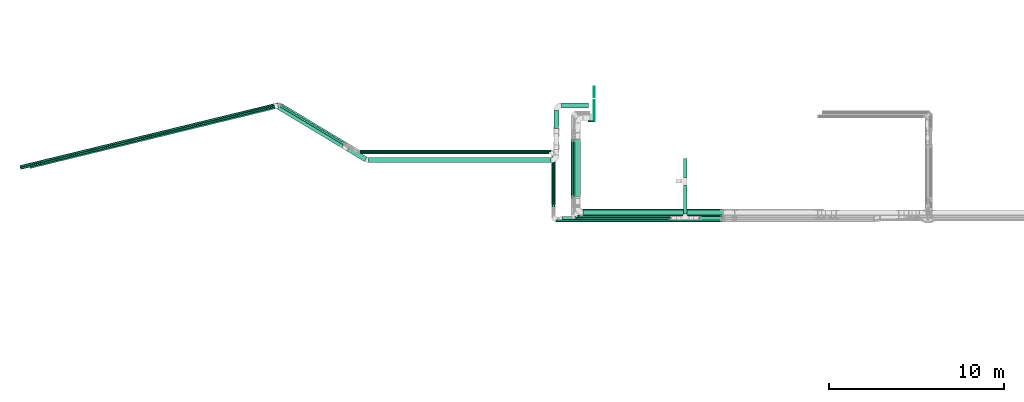
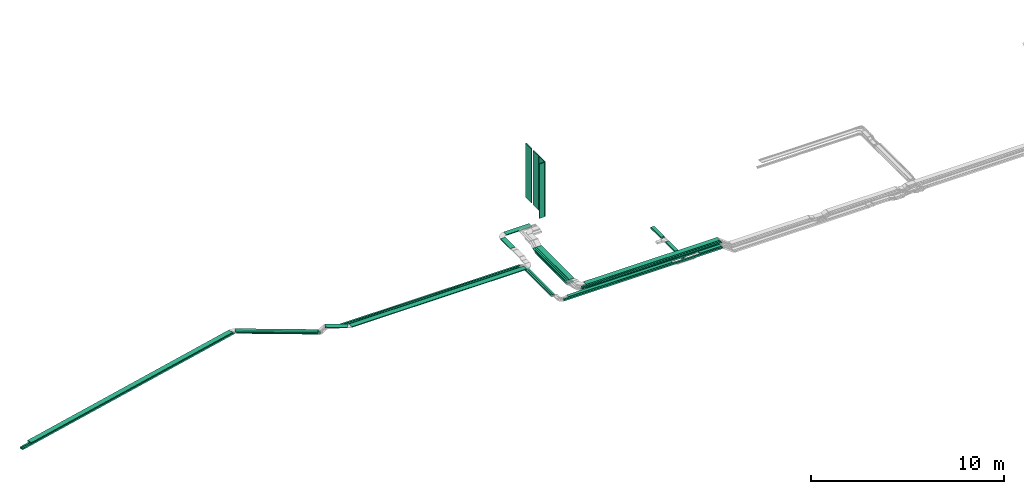
# One storey, part 1 of 27: 31 flow segments.
"""IFC2X3 building model written with IfcOpenShell, lengths in millimetres."""

import ifcopenshell
import ifcopenshell.guid

model = None  # the IFC model being written
_history = None  # IfcOwnerHistory: only IFC2X3 demands one
_inside = {}  # id of a spatial element -> (the spatial element, [elements in it])
_under = {}  # id of a project, library or spatial element -> (it, [spatial elements below it])
_declared = {}  # id of a project -> (the project, [libraries it declares])
_typed = {}  # id of a type object -> (the type object, [elements of that type])
_made_of = {}  # id of a material, layer set ... -> (it, [elements and type objects made of it])


def new_model(schema):
    """Start an empty IFC model of exactly this schema.

    Asked for "IFC4X3", IfcOpenShell would pick the latest addendum, in which some entities
    have other attributes; the version numbers below select the first issue.
    IFC2X3 requires an IfcOwnerHistory on every rooted entity: one is made here for all.
    """
    global model, _history
    if schema == "IFC4X3":
        model = ifcopenshell.file(schema_version=(4, 3, 0, 0))
    else:
        model = ifcopenshell.file(schema=schema)
    _inside.clear()
    _under.clear()
    _declared.clear()
    _typed.clear()
    _made_of.clear()
    _history = None
    if model.schema == "IFC2X3":
        org = make("IfcOrganization", Name="unknown")
        user = make(
            "IfcPersonAndOrganization",
            ThePerson=make("IfcPerson", FamilyName="unknown"),
            TheOrganization=org,
        )
        app = make(
            "IfcApplication",
            ApplicationDeveloper=org,
            Version="unknown",
            ApplicationFullName="unknown",
            ApplicationIdentifier="unknown",
        )
        _history = make(
            "IfcOwnerHistory",
            OwningUser=user,
            OwningApplication=app,
            ChangeAction="ADDED",
            CreationDate=0,
        )
    return model


def make(cls, **values):
    """One entity of the class cls with the attributes given. An attribute that is None is left unset."""
    return model.create_entity(
        cls, **{name: value for name, value in values.items() if value is not None}
    )


def entity(cls, *values):
    """Any entity or typed value of the class cls, its attributes in the order of the schema. None: left unset."""
    e = model.create_entity(cls)
    for i, value in enumerate(values):
        if value is not None:
            e[i] = value
    return e


def rooted(cls, **values):
    """An entity with a GlobalId (a new one), such as an element, a storey or a relation."""
    return make(cls, GlobalId=ifcopenshell.guid.new(), OwnerHistory=_history, **values)


def si_unit(unit_type, name, prefix=None):
    """IfcSIUnit, for example si_unit("LENGTHUNIT", "METRE", prefix="MILLI")."""
    return make("IfcSIUnit", UnitType=unit_type, Prefix=prefix, Name=name)


def converted_unit(unit_type, name, factor, base, dimensions=None, offset=None):
    """IfcConversionBasedUnit, such as the inch: factor (a typed value) times the base unit."""
    return make(
        "IfcConversionBasedUnit"
        if offset is None
        else "IfcConversionBasedUnitWithOffset",
        ConversionOffset=offset,
        Dimensions=None
        if dimensions is None
        else entity("IfcDimensionalExponents", *dimensions),
        UnitType=unit_type,
        Name=name,
        ConversionFactor=make(
            "IfcMeasureWithUnit", ValueComponent=factor, UnitComponent=base
        ),
    )


def derived_unit(unit_type, elements):
    """IfcDerivedUnit: a product of units, each with its exponent."""
    return make(
        "IfcDerivedUnit",
        Elements=[
            make("IfcDerivedUnitElement", Unit=unit, Exponent=power)
            for unit, power in elements
        ],
        UnitType=unit_type,
    )


def assignment(units):
    """IfcUnitAssignment: the units of a project."""
    return None if units is None else make("IfcUnitAssignment", Units=units)


def point(xyz):
    """IfcCartesianPoint."""
    return None if xyz is None else make("IfcCartesianPoint", Coordinates=xyz)


def direction(xyz):
    """IfcDirection."""
    return None if xyz is None else make("IfcDirection", DirectionRatios=xyz)


def frame(location, z_axis=None, x_axis=None):
    """IfcAxis2Placement3D, a coordinate frame: its origin and axes. An axis left out is left unset."""
    return make(
        "IfcAxis2Placement3D",
        Location=point(location),
        Axis=direction(z_axis),
        RefDirection=direction(x_axis),
    )


def frame_2d(location, x_axis=None):
    """IfcAxis2Placement2D, a coordinate frame in the plane: its origin and x axis."""
    return make(
        "IfcAxis2Placement2D", Location=point(location), RefDirection=direction(x_axis)
    )


def origin():
    """The frame at (0, 0, 0) with its axes left unset."""
    return frame((0.0, 0.0, 0.0))


def origin_2d_with_axis():
    """The frame at (0, 0) in the plane with the x axis (1, 0) written out."""
    return frame_2d((0.0, 0.0), x_axis=(1.0, 0.0))


def place(relative_to, where):
    """IfcLocalPlacement: puts the frame where relative to a parent placement (None: the world)."""
    return make(
        "IfcLocalPlacement", PlacementRelTo=relative_to, RelativePlacement=where
    )


def context(
    kind, dimensions, precision=None, world=None, true_north=None, identifier=None
):
    """IfcGeometricRepresentationContext, for example the 3D "Model" context."""
    return make(
        "IfcGeometricRepresentationContext",
        ContextIdentifier=identifier,
        ContextType=kind,
        CoordinateSpaceDimension=dimensions,
        Precision=precision,
        WorldCoordinateSystem=world,
        TrueNorth=true_north,
    )


def subcontext(parent, identifier, kind, view, scale=None):
    """IfcGeometricRepresentationSubContext, for example "Body" below "Model"."""
    return make(
        "IfcGeometricRepresentationSubContext",
        ContextIdentifier=identifier,
        ContextType=kind,
        ParentContext=parent,
        TargetScale=scale,
        TargetView=view,
    )


def project(units=None, contexts=None):
    """IfcProject with its units and contexts."""
    return rooted(
        "IfcProject",
        Name="project",
        RepresentationContexts=contexts,
        UnitsInContext=assignment(units),
    )


def spatial(cls, under=None, at=None, **own):
    """A site, building, storey or space (cls), placed at a placement, below another one or the project."""
    s = rooted(cls, ObjectPlacement=at, **own)
    if under is not None:
        _under.setdefault(under.id(), (under, []))[1].append(s)
    return s


def profile(cls, at=None, kind="AREA", **sizes):
    """A parametric profile (cls). Its sizes go by their IFC names, for example OverallWidth=200.0."""
    return make(cls, ProfileType=kind, Position=at, **sizes)


def rectangle(**sizes):
    """IfcRectangleProfileDef."""
    return profile("IfcRectangleProfileDef", **sizes)


def extrude(swept, where, along, depth):
    """IfcExtrudedAreaSolid: the profile swept, set in the frame where, extruded along a direction by depth."""
    return make(
        "IfcExtrudedAreaSolid",
        SweptArea=swept,
        Position=where,
        ExtrudedDirection=direction(along),
        Depth=depth,
    )


def shape(context_of_items, identifier, shape_type, items):
    """IfcShapeRepresentation: the items that make up one representation, for example the "Body"."""
    return make(
        "IfcShapeRepresentation",
        ContextOfItems=context_of_items,
        RepresentationIdentifier=identifier,
        RepresentationType=shape_type,
        Items=items,
    )


def made_of(thing, what):
    """Note that an element or type object is made of a material, layer set ...; save() writes the relation."""
    if what is not None:
        _made_of.setdefault(what.id(), (what, []))[1].append(thing)
    return thing


def type_object(cls, material=None, **own):
    """A type object (cls), such as IfcWallType, which elements share."""
    return made_of(rooted(cls, **own), material)


def element(
    cls,
    number,
    at=None,
    inside=None,
    cuts=None,
    type_object=None,
    material=None,
    context=None,
    identifier="Body",
    shape_type=None,
    held_by="IfcProductDefinitionShape",
    body=None,
    shapes=None,
    **own,
):
    """One element of the class cls, such as IfcWall. Its Tag is "e" and its number.

    at: its placement. inside: the storey or other place that contains it. cuts: it is an
    opening in that element (IfcRelVoidsElement). A single representation is given by context,
    identifier, shape_type and body (its items); several are given by shapes. held_by: the class
    of the entity that holds the representations. save() writes the other relations.
    """
    e = rooted(cls, Tag="e%d" % number, ObjectPlacement=at, **own)
    if body is not None:
        shapes = [shape(context, identifier, shape_type, body)]
    if shapes is not None:
        e.Representation = make(held_by, Representations=shapes)
    if inside is not None:
        _inside.setdefault(inside.id(), (inside, []))[1].append(e)
    if cuts is not None:
        rooted(
            "IfcRelVoidsElement", RelatingBuildingElement=cuts, RelatedOpeningElement=e
        )
    if type_object is not None:
        _typed.setdefault(type_object.id(), (type_object, []))[1].append(e)
    return made_of(e, material)


def aggregate(whole, parts):
    """IfcRelAggregates: a whole, such as a stair, and the parts it consists of."""
    return rooted("IfcRelAggregates", RelatingObject=whole, RelatedObjects=parts)


def save(model, path):
    """Write the relations noted so far, then the file.

    IfcRelAggregates (storeys below a building ...), IfcRelContainedInSpatialStructure (elements
    in a storey), IfcRelDefinesByType, IfcRelAssociatesMaterial and IfcRelDeclares: one each for
    every whole, place, type object, material and project.
    """
    for whole, parts in _under.values():
        aggregate(whole, parts)
    for where, things in _inside.values():
        rooted(
            "IfcRelContainedInSpatialStructure",
            RelatedElements=things,
            RelatingStructure=where,
        )
    for kind, things in _typed.values():
        rooted("IfcRelDefinesByType", RelatedObjects=things, RelatingType=kind)
    for what, things in _made_of.values():
        rooted("IfcRelAssociatesMaterial", RelatedObjects=things, RelatingMaterial=what)
    for by, libraries in _declared.values():
        rooted("IfcRelDeclares", RelatingContext=by, RelatedDefinitions=libraries)
    model.write(path)


model = new_model("IFC2X3")

# Units and contexts
model_context = context("Model", 3, precision=0.01, world=origin(), true_north=direction((6.12303176911189e-17, 1.0)))
body_context = subcontext(model_context, "Body", "Model", "MODEL_VIEW")
ifc_project = project(units=[si_unit("LENGTHUNIT", "METRE", prefix="MILLI"), si_unit("AREAUNIT", "SQUARE_METRE"), si_unit("VOLUMEUNIT", "CUBIC_METRE"), converted_unit("PLANEANGLEUNIT", "DEGREE", entity("IfcRatioMeasure", 0.0174532925199433), si_unit("PLANEANGLEUNIT", "RADIAN"), dimensions=[0, 0, 0, 0, 0, 0, 0]), si_unit("MASSUNIT", "GRAM", prefix="KILO"), derived_unit("MASSDENSITYUNIT", [(si_unit("MASSUNIT", "GRAM", prefix="KILO"), 1), (si_unit("LENGTHUNIT", "METRE"), -3)]), derived_unit("MOMENTOFINERTIAUNIT", [(si_unit("LENGTHUNIT", "METRE"), 4)]), si_unit("TIMEUNIT", "SECOND"), si_unit("FREQUENCYUNIT", "HERTZ"), si_unit("THERMODYNAMICTEMPERATUREUNIT", "DEGREE_CELSIUS"), derived_unit("THERMALTRANSMITTANCEUNIT", [(si_unit("MASSUNIT", "GRAM", prefix="KILO"), 1), (si_unit("THERMODYNAMICTEMPERATUREUNIT", "KELVIN"), -1), (si_unit("TIMEUNIT", "SECOND"), -3)]), derived_unit("VOLUMETRICFLOWRATEUNIT", [(si_unit("LENGTHUNIT", "METRE"), 3), (si_unit("TIMEUNIT", "SECOND"), -1)]), derived_unit("MASSFLOWRATEUNIT", [(si_unit("MASSUNIT", "GRAM", prefix="KILO"), 1), (si_unit("TIMEUNIT", "SECOND"), -1)]), derived_unit("ROTATIONALFREQUENCYUNIT", [(si_unit("TIMEUNIT", "SECOND"), -1)]), si_unit("ELECTRICCURRENTUNIT", "AMPERE"), si_unit("ELECTRICVOLTAGEUNIT", "VOLT"), si_unit("POWERUNIT", "WATT"), si_unit("FORCEUNIT", "NEWTON", prefix="KILO"), si_unit("ILLUMINANCEUNIT", "LUX"), si_unit("LUMINOUSFLUXUNIT", "LUMEN"), si_unit("LUMINOUSINTENSITYUNIT", "CANDELA"), derived_unit("USERDEFINED", [(si_unit("MASSUNIT", "GRAM", prefix="KILO"), -1), (si_unit("LENGTHUNIT", "METRE"), -2), (si_unit("TIMEUNIT", "SECOND"), 3), (si_unit("LUMINOUSFLUXUNIT", "LUMEN"), 1)]), derived_unit("LINEARVELOCITYUNIT", [(si_unit("LENGTHUNIT", "METRE"), 1), (si_unit("TIMEUNIT", "SECOND"), -1)]), si_unit("PRESSUREUNIT", "PASCAL"), derived_unit("USERDEFINED", [(si_unit("LENGTHUNIT", "METRE"), -2), (si_unit("MASSUNIT", "GRAM", prefix="KILO"), 1), (si_unit("TIMEUNIT", "SECOND"), -2)]), derived_unit("LINEARFORCEUNIT", [(si_unit("MASSUNIT", "GRAM", prefix="KILO"), 1), (si_unit("LENGTHUNIT", "METRE"), 1), (si_unit("TIMEUNIT", "SECOND"), -2), (si_unit("LENGTHUNIT", "METRE"), -1)]), derived_unit("PLANARFORCEUNIT", [(si_unit("MASSUNIT", "GRAM", prefix="KILO"), 1), (si_unit("LENGTHUNIT", "METRE"), 1), (si_unit("TIMEUNIT", "SECOND"), -2), (si_unit("LENGTHUNIT", "METRE"), -2)])], contexts=[model_context])

# Site, building, storey
site_placement = place(None, origin())
site = spatial("IfcSite", under=ifc_project, at=site_placement, CompositionType="ELEMENT")
building_placement = place(site_placement, origin())
building = spatial("IfcBuilding", under=site, at=building_placement, CompositionType="ELEMENT")
storey_placement = place(building_placement, origin())
storey = spatial("IfcBuildingStorey", under=building, at=storey_placement, CompositionType="ELEMENT", Elevation=0.0)

# Flow segments
cable_carrier_segment_type_1 = type_object("IfcCableCarrierSegmentType", PredefinedType="CABLETRAYSEGMENT")
flow_segment_1_placement = place(storey_placement, frame((15851.0, 8570.0, 3100.0)))
element("IfcFlowSegment", 1, at=flow_segment_1_placement, inside=storey, type_object=cable_carrier_segment_type_1, context=body_context, shape_type="SweptSolid", body=[
    extrude(rectangle(XDim=7974.65921899979, YDim=400.0, at=origin_2d_with_axis()), frame((3987.33, 200.0, 0.0)), (0.0, 0.0, 1.0), 100.0),
])
flow_segment_2_placement = place(storey_placement, frame((21593.6, 10793.36, 2950.0)))
element("IfcFlowSegment", 2, at=flow_segment_2_placement, inside=storey, type_object=cable_carrier_segment_type_1, context=body_context, shape_type="SweptSolid", body=[
    extrude(rectangle(XDim=1071.71608612061, YDim=199.999999999998, at=origin_2d_with_axis()), frame((100.0, 535.86, 0.0), z_axis=(0.0, 0.0, 1.0), x_axis=(0.0, -1.0, 0.0)), (0.0, 0.0, 1.0), 99.9999999999995),
])
flow_segment_3_placement = place(storey_placement, frame((14644.72, 8360.0, 3100.0)))
element("IfcFlowSegment", 3, at=flow_segment_3_placement, inside=storey, type_object=cable_carrier_segment_type_1, context=body_context, shape_type="SweptSolid", body=[
    extrude(rectangle(XDim=6224.94739294661, YDim=200.0, at=origin_2d_with_axis()), frame((3112.47, 100.0, 0.0)), (0.0, 0.0, 1.0), 100.0),
])
flow_segment_4_placement = place(storey_placement, frame((14163.72, 9105.62, 2950.0)))
element("IfcFlowSegment", 4, at=flow_segment_4_placement, inside=storey, type_object=cable_carrier_segment_type_1, context=body_context, shape_type="SweptSolid", body=[
    extrude(rectangle(XDim=2998.38255226861, YDim=99.9999999999989, at=origin_2d_with_axis()), frame((50.0, 1499.19, 0.0), z_axis=(0.0, 0.0, 1.0), x_axis=(0.0, -1.0, 0.0)), (0.0, 0.0, 1.0), 100.0),
])
flow_segment_5_placement = place(storey_placement, frame((3071.29, 12255.0, 2950.0)))
element("IfcFlowSegment", 5, at=flow_segment_5_placement, inside=storey, type_object=cable_carrier_segment_type_1, context=body_context, shape_type="SweptSolid", body=[
    extrude(rectangle(XDim=10941.4294128361, YDim=99.9999999999989, at=origin_2d_with_axis()), frame((5470.71, 50.0, 0.0), z_axis=(0.0, 0.0, 1.0), x_axis=(-1.0, 0.0, 0.0)), (0.0, 0.0, 1.0), 100.0),
])
flow_segment_6_placement = place(storey_placement, frame((-1476.17, 12676.61, 2600.0)))
element("IfcFlowSegment", 6, at=flow_segment_6_placement, inside=storey, type_object=cable_carrier_segment_type_1, context=body_context, shape_type="SweptSolid", body=[
    extrude(rectangle(XDim=4404.58031867628, YDim=99.9999999999999, at=origin_2d_with_axis()), frame((1913.48, 1177.12, 0.0), z_axis=(0.0, 0.0, 1.0), x_axis=(0.857167300702113, -0.515038074910054, 0.0)), (0.0, 0.0, 1.0), 100.0),
])
flow_segment_7_placement = place(storey_placement, frame((-16390.68, 11360.8, 2600.0)))
element("IfcFlowSegment", 7, at=flow_segment_7_placement, inside=storey, type_object=cable_carrier_segment_type_1, context=body_context, shape_type="SweptSolid", body=[
    extrude(rectangle(XDim=15208.8618462409, YDim=99.9999999999989, at=origin_2d_with_axis()), frame((7399.95, 1849.46, 0.0), z_axis=(0.0, 0.0, 1.0), x_axis=(-0.97155336378743, -0.236820736662416, 0.0)), (0.0, 0.0, 1.0), 100.0),
])
flow_segment_8_placement = place(storey_placement, frame((14304.72, 8250.0, 3100.0)))
element("IfcFlowSegment", 8, at=flow_segment_8_placement, inside=storey, type_object=cable_carrier_segment_type_1, context=body_context, shape_type="SweptSolid", body=[
    extrude(rectangle(XDim=9520.9318527469, YDim=99.9999999999989, at=origin_2d_with_axis()), frame((4760.47, 50.0, 0.0)), (0.0, 0.0, 1.0), 100.0),
])
flow_segment_9_placement = place(storey_placement, frame((14053.72, 9105.62, 2950.0)))
element("IfcFlowSegment", 9, at=flow_segment_9_placement, inside=storey, type_object=cable_carrier_segment_type_1, context=body_context, shape_type="SweptSolid", body=[
    extrude(rectangle(XDim=2878.38255226848, YDim=99.9999999999989, at=origin_2d_with_axis()), frame((50.0, 1439.19, 0.0), z_axis=(0.0, 0.0, 1.0), x_axis=(0.0, -1.0, 0.0)), (0.0, 0.0, 1.0), 100.0),
])
flow_segment_10_placement = place(storey_placement, frame((3057.43, 12135.0, 2950.0)))
element("IfcFlowSegment", 10, at=flow_segment_10_placement, inside=storey, type_object=cable_carrier_segment_type_1, context=body_context, shape_type="SweptSolid", body=[
    extrude(rectangle(XDim=10845.2923178592, YDim=99.9999999999989, at=origin_2d_with_axis()), frame((5422.65, 50.0, 0.0), z_axis=(0.0, 0.0, 1.0), x_axis=(-1.0, 0.0, 0.0)), (0.0, 0.0, 1.0), 100.0),
])
flow_segment_11_placement = place(storey_placement, frame((-1494.06, 12582.32, 2600.0)))
element("IfcFlowSegment", 11, at=flow_segment_11_placement, inside=storey, type_object=cable_carrier_segment_type_1, context=body_context, shape_type="SweptSolid", body=[
    extrude(rectangle(XDim=4359.35500303556, YDim=100.0, at=origin_2d_with_axis()), frame((1894.1, 1165.48, 0.0), z_axis=(0.0, 0.0, 1.0), x_axis=(0.857167300702109, -0.51503807491006, 0.0)), (0.0, 0.0, 1.0), 100.0),
])
flow_segment_12_placement = place(storey_placement, frame((-16364.63, 11253.93, 2600.0)))
element("IfcFlowSegment", 12, at=flow_segment_12_placement, inside=storey, type_object=cable_carrier_segment_type_1, context=body_context, shape_type="SweptSolid", body=[
    extrude(rectangle(XDim=15163.6365305987, YDim=99.9999999999992, at=origin_2d_with_axis()), frame((7377.98, 1844.11, 0.0), z_axis=(0.0, 0.0, 1.0), x_axis=(-0.97155336378743, -0.236820736662417, 0.0)), (0.0, 0.0, 1.0), 99.9999999999999),
])
flow_segment_13_placement = place(storey_placement, frame((15290.0, 9581.08, 3230.0)))
element("IfcFlowSegment", 13, at=flow_segment_13_placement, inside=storey, type_object=cable_carrier_segment_type_1, context=body_context, shape_type="SweptSolid", body=[
    extrude(rectangle(XDim=3404.78726853567, YDim=99.9999999999989, at=origin_2d_with_axis()), frame((50.0, 1702.39, 0.0), z_axis=(0.0, 0.0, 1.0), x_axis=(0.0, 1.0, 0.0)), (0.0, 0.0, 1.0), 50.0000000000005),
])
flow_segment_14_placement = place(storey_placement, frame((15180.0, 9581.08, 3230.0)))
element("IfcFlowSegment", 14, at=flow_segment_14_placement, inside=storey, type_object=cable_carrier_segment_type_1, context=body_context, shape_type="SweptSolid", body=[
    extrude(rectangle(XDim=3404.78726853591, YDim=99.9999999999989, at=origin_2d_with_axis()), frame((50.0, 1702.39, 0.0), z_axis=(0.0, 0.0, 1.0), x_axis=(0.0, 1.0, 0.0)), (0.0, 0.0, 1.0), 50.0000000000005),
])
flow_segment_15_placement = place(storey_placement, frame((22517.53, 8360.0, 3100.0)))
element("IfcFlowSegment", 15, at=flow_segment_15_placement, inside=storey, type_object=cable_carrier_segment_type_1, context=body_context, shape_type="SweptSolid", body=[
    extrude(rectangle(XDim=1308.13077267465, YDim=200.0, at=origin_2d_with_axis()), frame((654.07, 100.0, 0.0)), (0.0, 0.0, 1.0), 100.0),
])
flow_segment_16_placement = place(storey_placement, frame((21593.6, 8690.0, 2950.0)))
element("IfcFlowSegment", 16, at=flow_segment_16_placement, inside=storey, type_object=cable_carrier_segment_type_1, context=body_context, shape_type="SweptSolid", body=[
    extrude(rectangle(XDim=1643.36443772362, YDim=199.999999999998, at=origin_2d_with_axis()), frame((100.0, 821.68, 0.0), z_axis=(0.0, 0.0, 1.0), x_axis=(0.0, -1.0, 0.0)), (0.0, 0.0, 1.0), 100.0),
])
flow_segment_17_placement = place(storey_placement, frame((15400.0, 9581.08, 3230.0)))
element("IfcFlowSegment", 17, at=flow_segment_17_placement, inside=storey, type_object=cable_carrier_segment_type_1, context=body_context, shape_type="SweptSolid", body=[
    extrude(rectangle(XDim=3404.78726853175, YDim=300.000000000001, at=origin_2d_with_axis()), frame((150.0, 1702.39, 0.0), z_axis=(0.0, 0.0, 1.0), x_axis=(0.0, -1.0, 0.0)), (0.0, 0.0, 1.0), 49.9999999999995),
])
flow_segment_18_placement = place(storey_placement, frame((14631.0, 14757.61, 3200.0)))
element("IfcFlowSegment", 18, at=flow_segment_18_placement, inside=storey, type_object=cable_carrier_segment_type_1, context=body_context, shape_type="SweptSolid", body=[
    extrude(rectangle(XDim=1526.30884229986, YDim=300.000000000001, at=origin_2d_with_axis()), frame((763.15, 150.0, 0.0), z_axis=(0.0, 0.0, 1.0), x_axis=(-1.0, 0.0, 0.0)), (0.0, 0.0, 1.0), 49.9999999999995),
])
flow_segment_19_placement = place(storey_placement, frame((3570.13, 11625.27, 3150.0)))
element("IfcFlowSegment", 19, at=flow_segment_19_placement, inside=storey, type_object=cable_carrier_segment_type_1, context=body_context, shape_type="SweptSolid", body=[
    extrude(rectangle(XDim=10458.8647674354, YDim=300.000000000001, at=origin_2d_with_axis()), frame((5229.43, 150.0, 0.0), z_axis=(0.0, 0.0, 1.0), x_axis=(-1.0, 0.0, 0.0)), (0.0, 0.0, 1.0), 49.9999999999995),
])
flow_segment_20_placement = place(storey_placement, frame((15851.0, 8620.0, 3350.0)))
element("IfcFlowSegment", 20, at=flow_segment_20_placement, inside=storey, type_object=cable_carrier_segment_type_1, context=body_context, shape_type="SweptSolid", body=[
    extrude(rectangle(XDim=8009.29673573433, YDim=299.999999999999, at=origin_2d_with_axis()), frame((4004.65, 150.0, 0.0)), (0.0, 0.0, 1.0), 50.0000000000005),
])
flow_segment_21_placement = place(storey_placement, frame((15541.0, 8510.0, 3350.0)))
element("IfcFlowSegment", 21, at=flow_segment_21_placement, inside=storey, type_object=cable_carrier_segment_type_1, context=body_context, shape_type="SweptSolid", body=[
    extrude(rectangle(XDim=8319.2967357344, YDim=99.9999999999989, at=origin_2d_with_axis()), frame((4159.65, 50.0, 0.0)), (0.0, 0.0, 1.0), 50.0000000000005),
])
flow_segment_22_placement = place(storey_placement, frame((15431.0, 8400.0, 3350.0)))
element("IfcFlowSegment", 22, at=flow_segment_22_placement, inside=storey, type_object=cable_carrier_segment_type_1, context=body_context, shape_type="SweptSolid", body=[
    extrude(rectangle(XDim=8429.29673573445, YDim=99.9999999999989, at=origin_2d_with_axis()), frame((4214.65, 50.0, 0.0)), (0.0, 0.0, 1.0), 50.0000000000005),
])
flow_segment_23_placement = place(storey_placement, frame((15300.0, 9660.36, 2940.0)))
element("IfcFlowSegment", 23, at=flow_segment_23_placement, inside=storey, type_object=cable_carrier_segment_type_1, context=body_context, shape_type="SweptSolid", body=[
    extrude(rectangle(XDim=3284.22401747535, YDim=400.0, at=origin_2d_with_axis()), frame((200.0, 1642.11, 0.0), z_axis=(0.0, 0.0, 1.0), x_axis=(0.0, -1.0, 0.0)), (0.0, 0.0, 1.0), 100.0),
])
flow_segment_24_placement = place(storey_placement, frame((14180.0, 13577.12, 3200.0)))
element("IfcFlowSegment", 24, at=flow_segment_24_placement, inside=storey, type_object=cable_carrier_segment_type_1, context=body_context, shape_type="SweptSolid", body=[
    extrude(rectangle(XDim=1029.48573385168, YDim=300.000000000001, at=origin_2d_with_axis()), frame((150.0, 514.74, 0.0), z_axis=(0.0, 0.0, 1.0), x_axis=(0.0, -1.0, 0.0)), (0.0, 0.0, 1.0), 50.0000000000005),
])
flow_segment_25_placement = place(storey_placement, frame((2333.9, 11690.06, 3150.0)))
element("IfcFlowSegment", 25, at=flow_segment_25_placement, inside=storey, type_object=cable_carrier_segment_type_1, context=body_context, shape_type="SweptSolid", body=[
    extrude(rectangle(XDim=1169.67695262687, YDim=299.999999999999, at=origin_2d_with_axis()), frame((578.56, 429.79, 0.0), z_axis=(0.0, 0.0, 1.0), x_axis=(-0.857167300702099, 0.515038074910076, 0.0)), (0.0, 0.0, 1.0), 49.9999999999995),
])
flow_segment_26_placement = place(storey_placement, frame((-1662.61, 12469.13, 2800.0)))
element("IfcFlowSegment", 26, at=flow_segment_26_placement, inside=storey, type_object=cable_carrier_segment_type_1, context=body_context, shape_type="SweptSolid", body=[
    extrude(rectangle(XDim=4319.50148221799, YDim=300.000000000002, at=origin_2d_with_axis()), frame((1928.52, 1240.93, 0.0), z_axis=(0.0, 0.0, 1.0), x_axis=(-0.857167300702108, 0.515038074910062, 0.0)), (0.0, 0.0, 1.0), 50.0000000000005),
])
flow_segment_27_placement = place(storey_placement, frame((-15874.31, 11292.36, 2800.0)))
element("IfcFlowSegment", 27, at=flow_segment_27_placement, inside=storey, type_object=cable_carrier_segment_type_1, context=body_context, shape_type="SweptSolid", body=[
    extrude(rectangle(XDim=14436.7145710913, YDim=299.999999999999, at=origin_2d_with_axis()), frame((7048.54, 1855.19, 0.0), z_axis=(0.0, 0.0, 1.0), x_axis=(-0.971553363787423, -0.236820736662447, 0.0)), (0.0, 0.0, 1.0), 49.9999999999994),
])
cable_carrier_segment_type_2 = type_object("IfcCableCarrierSegmentType", PredefinedType="CABLETRAYSEGMENT")
for number, where in (
    (28, (16472.31, 15367.61, 4230.84)),
    (29, (16472.31, 14607.61, 4230.84)),
):
    element("IfcFlowSegment", number, at=place(storey_placement, frame(where)), inside=storey, type_object=cable_carrier_segment_type_2, context=body_context, shape_type="SweptSolid", body=[
        extrude(rectangle(XDim=50.0000000000016, YDim=600.000000000002, at=origin_2d_with_axis()), frame((25.0, 300.0, 0.0), z_axis=(0.0, 0.0, 1.0), x_axis=(-1.0, 0.0, 0.0)), (0.0, 0.0, 1.0), 3440.0),
    ])
flow_segment_28_placement = place(storey_placement, frame((16472.31, 13987.61, 4230.84)))
element("IfcFlowSegment", 30, at=flow_segment_28_placement, inside=storey, type_object=cable_carrier_segment_type_2, context=body_context, shape_type="SweptSolid", body=[
    extrude(rectangle(XDim=50.0000000000016, YDim=599.999999999998, at=origin_2d_with_axis()), frame((25.0, 300.0, 0.0), z_axis=(0.0, 0.0, 1.0), x_axis=(-1.0, 0.0, 0.0)), (0.0, 0.0, 1.0), 3440.0),
])
flow_segment_29_placement = place(storey_placement, frame((16147.31, 13967.61, 4225.84)))
element("IfcFlowSegment", 31, at=flow_segment_29_placement, inside=storey, type_object=cable_carrier_segment_type_2, context=body_context, shape_type="SweptSolid", body=[
    extrude(rectangle(XDim=50.0000000000016, YDim=300.000000000001, at=origin_2d_with_axis()), frame((150.0, 25.0, 0.0), z_axis=(0.0, 0.0, 1.0), x_axis=(0.0, 1.0, 0.0)), (0.0, 0.0, 1.0), 3445.0),
])

save(model, "model.ifc")
